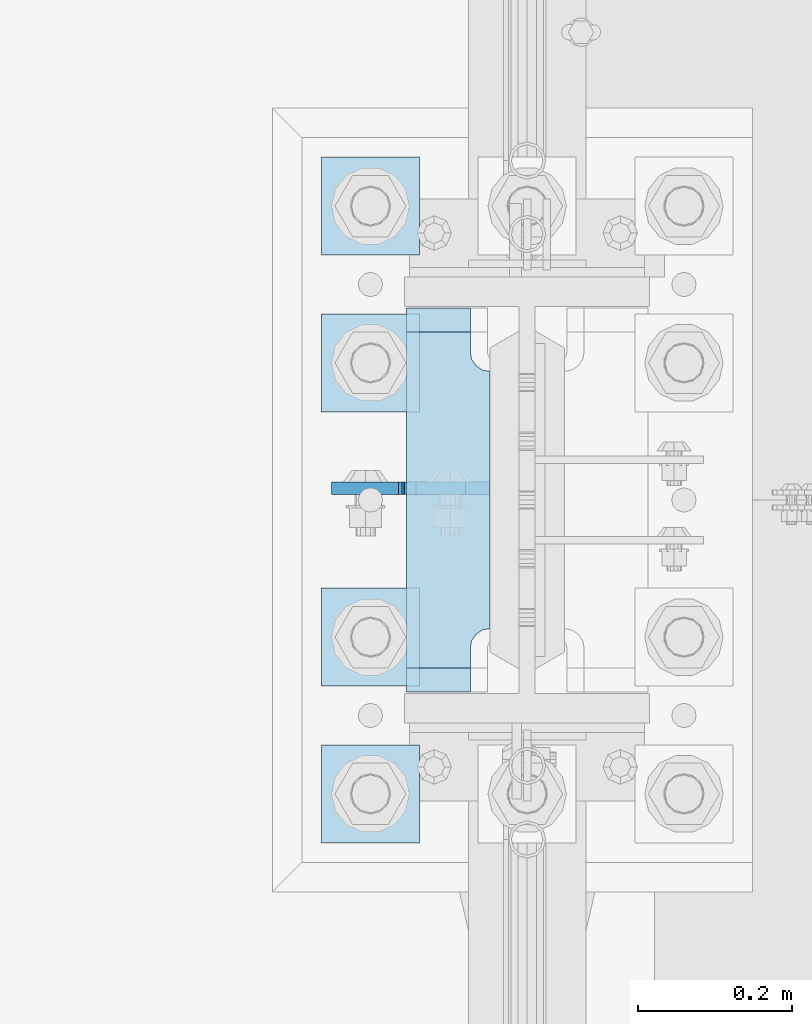
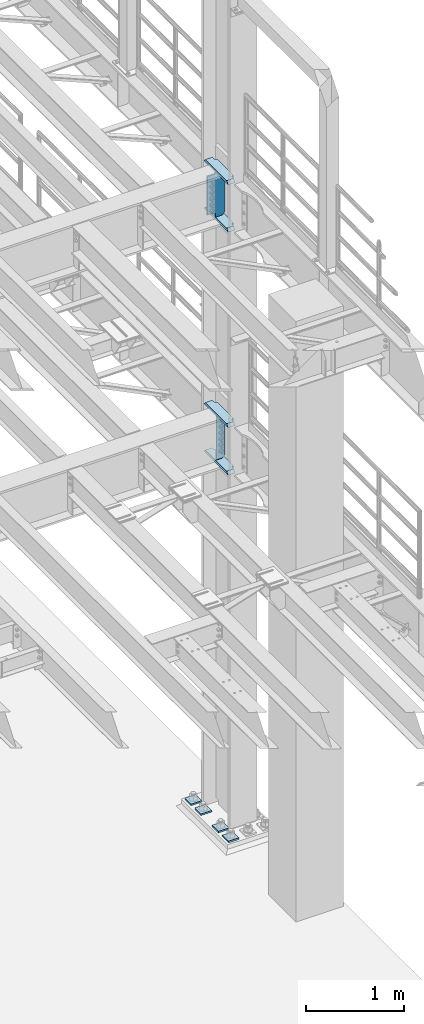
# One storey, part 1736 of 1876: 10 plates, 2 elements without a shape of their own.
"""IFC2X3 building model written with IfcOpenShell, lengths in millimetres."""

from ifc_helpers import new_model, si_unit, frame, origin_with_axes, place, context, subcontext, project, spatial, faceted_brep, material, type_object, element, aggregate, save


model = new_model("IFC2X3")

# Units and contexts
model_context = context("Model", 3, precision=1e-05, world=origin_with_axes())
body_context = subcontext(model_context, "Body", "Model", "MODEL_VIEW")
ifc_project = project(units=[si_unit("LENGTHUNIT", "METRE", prefix="MILLI"), si_unit("AREAUNIT", "SQUARE_METRE"), si_unit("VOLUMEUNIT", "CUBIC_METRE"), si_unit("MASSUNIT", "GRAM", prefix="KILO"), si_unit("TIMEUNIT", "SECOND"), si_unit("PLANEANGLEUNIT", "RADIAN"), si_unit("SOLIDANGLEUNIT", "STERADIAN"), si_unit("THERMODYNAMICTEMPERATUREUNIT", "DEGREE_CELSIUS"), si_unit("LUMINOUSINTENSITYUNIT", "LUMEN")], contexts=[model_context])

# Site, building, storey
site_placement = place(None, origin_with_axes())
site = spatial("IfcSite", under=ifc_project, at=site_placement, CompositionType="ELEMENT")
building_placement = place(site_placement, origin_with_axes())
building = spatial("IfcBuilding", under=site, at=building_placement, Name="Undefined", CompositionType="ELEMENT")
storey_placement = place(building_placement, origin_with_axes())
storey = spatial("IfcBuildingStorey", under=building, at=storey_placement, Name="Undefined", CompositionType="ELEMENT", Elevation=0.0)

# Assembly, plates
assembly_1_placement = place(storey_placement, origin_with_axes())
assembly_1 = element("IfcElementAssembly", 1, at=assembly_1_placement, inside=storey, Name="COLUMN", AssemblyPlace="NOTDEFINED", PredefinedType="RIGID_FRAME")
ifc_material_1 = material(Name="STEEL/A36")
plate_type_1 = type_object("IfcPlateType", PredefinedType="NOTDEFINED")
plate_1_placement = place(assembly_1_placement, frame((7571.58125, 7635.08050012589, 5099.05), z_axis=(-1.0, 0.0, 0.0), x_axis=(0.0, 0.0, -1.0)))
plate_1 = element("IfcPlate", 2, at=plate_1_placement, type_object=plate_type_1, material=ifc_material_1, Name="PLATE", context=body_context, shape_type="Brep", body=[
    faceted_brep([(0.0, -7.93749999999998, 31.75), (0.0, -7.9375, 96.0437469482422), (0.0, 7.9375, 96.0437469482422), (0.0, 7.93749999999999, 31.75), (558.799987792969, -7.9375, 96.0437469482422), (558.799987792969, 7.9375, 96.0437469482422), (558.799987792969, -7.93749999999998, 31.75), (558.799987792969, 7.93749999999999, 31.75), (527.049987792969, -7.93749999999998, 0.0), (527.049987792969, 7.93749999999999, 0.0), (31.75, -7.93749999999998, 0.0), (31.75, 7.93749999999999, 0.0)], [[[0, 1, 2, 3]], [[1, 4, 5, 2]], [[4, 6, 7, 5]], [[6, 8, 9, 7]], [[8, 10, 11, 9]], [[10, 0, 3, 11]], [[5, 7, 9, 11, 3, 2]], [[10, 8, 6, 4, 1, 0]]]),
])
ifc_material_2 = material(Name="STEEL/A572-50")
plate_type_2 = type_object("IfcPlateType", PredefinedType="NOTDEFINED")
plate_2_placement = place(assembly_1_placement, frame((7463.63125, 7869.2375, 7546.97501220703), z_axis=(0.0, -1.0, 0.0), x_axis=(1.0, 0.0, 0.0)))
plate_2 = element("IfcPlate", 3, at=plate_2_placement, type_object=plate_type_2, material=ifc_material_2, Name="PLATE", context=body_context, shape_type="Brep", body=[
    faceted_brep([(82.5499973297119, -15.875, 498.475006103516), (82.5499973297119, 15.875, 467.025007631571), (0.0, 15.875, 467.025007631571), (0.0, -15.875, 498.475006103516), (82.5499973297119, 15.875, 31.449998471945), (82.5499973297119, -15.875, 0.0), (0.0, -15.875, 0.0), (0.0, 15.875, 31.449998471945), (82.5499973297119, 15.875, 57.1500034332275), (82.5499973297119, -15.875, 57.1500034332275), (84.4834571748879, -15.875, 66.8701624693188), (84.4834571748879, 15.875, 66.8701624693188), (89.9894849758439, -15.875, 75.1105154056261), (89.9894849758439, 15.875, 75.1105154056261), (98.2298379121512, -15.875, 80.616543206582), (98.2298379121512, 15.875, 80.616543206582), (107.949996948242, -15.875, 82.5500030517578), (107.949996948242, 15.875, 82.5500030517578), (107.949996948242, -15.875, 415.925003051758), (107.949996948242, 15.875, 415.925003051758), (98.2298379121512, -15.875, 417.858462896934), (98.2298379121512, 15.875, 417.858462896934), (89.9894849758439, -15.875, 423.36449069789), (89.9894849758439, 15.875, 423.36449069789), (84.483457174887, -15.875, 431.604843634197), (84.483457174887, 15.875, 431.604843634197), (82.5499973297119, -15.875, 441.325002670288), (82.5499973297119, 15.875, 441.325002670288)], [[[0, 1, 2, 3]], [[4, 5, 6, 7]], [[8, 9, 5, 4]], [[10, 9, 8, 11]], [[12, 10, 11, 13]], [[14, 12, 13, 15]], [[16, 14, 15, 17]], [[18, 16, 17, 19]], [[20, 18, 19, 21]], [[22, 20, 21, 23]], [[24, 22, 23, 25]], [[26, 24, 25, 27]], [[6, 5, 9, 10, 12, 14, 16, 18, 20, 22, 24, 26, 0, 3]], [[7, 6, 3, 2]], [[27, 25, 23, 21, 19, 17, 15, 13, 11, 8, 4, 7, 2, 1]], [[26, 27, 1, 0]]]),
])
plate_3_placement = place(assembly_1_placement, frame((7463.63125, 7869.2375, 8137.525), z_axis=(0.0, -1.0, 0.0), x_axis=(1.0, 0.0, 0.0)))
plate_3 = element("IfcPlate", 4, at=plate_3_placement, type_object=plate_type_2, material=ifc_material_2, Name="PLATE", context=body_context, shape_type="Brep", body=[
    faceted_brep([(82.5499973297119, -15.875, 498.475006103516), (82.5499973297119, 15.875, 467.025007631571), (0.0, 15.875, 467.025007631571), (0.0, -15.875, 498.475006103516), (82.5499973297119, 15.875, 31.449998471945), (82.5499973297119, -15.875, 0.0), (0.0, -15.875, 0.0), (0.0, 15.875, 31.449998471945), (82.5499973297119, 15.875, 57.1500034332275), (82.5499973297119, -15.875, 57.1500034332275), (84.4834571748879, -15.875, 66.8701624693188), (84.4834571748879, 15.875, 66.8701624693188), (89.9894849758439, -15.875, 75.1105154056261), (89.9894849758439, 15.875, 75.1105154056261), (98.2298379121512, -15.875, 80.616543206582), (98.2298379121512, 15.875, 80.616543206582), (107.949996948242, -15.875, 82.5500030517578), (107.949996948242, 15.875, 82.5500030517578), (107.949996948242, -15.875, 415.925003051758), (107.949996948242, 15.875, 415.925003051758), (98.2298379121512, -15.875, 417.858462896934), (98.2298379121512, 15.875, 417.858462896934), (89.9894849758439, -15.875, 423.36449069789), (89.9894849758439, 15.875, 423.36449069789), (84.483457174887, -15.875, 431.604843634197), (84.483457174887, 15.875, 431.604843634197), (82.5499973297119, -15.875, 441.325002670288), (82.5499973297119, 15.875, 441.325002670288)], [[[0, 1, 2, 3]], [[4, 5, 6, 7]], [[8, 9, 5, 4]], [[10, 9, 8, 11]], [[12, 10, 11, 13]], [[14, 12, 13, 15]], [[16, 14, 15, 17]], [[18, 16, 17, 19]], [[20, 18, 19, 21]], [[22, 20, 21, 23]], [[24, 22, 23, 25]], [[26, 24, 25, 27]], [[6, 5, 9, 10, 12, 14, 16, 18, 20, 22, 24, 26, 0, 3]], [[7, 6, 3, 2]], [[27, 25, 23, 21, 19, 17, 15, 13, 11, 8, 4, 7, 2, 1]], [[26, 27, 1, 0]]]),
])
plate_4_placement = place(assembly_1_placement, frame((7463.63125, 7869.2375, 4524.37501220703), z_axis=(0.0, -1.0, 0.0), x_axis=(1.0, 0.0, 0.0)))
plate_4 = element("IfcPlate", 5, at=plate_4_placement, type_object=plate_type_2, material=ifc_material_2, Name="PLATE", context=body_context, shape_type="Brep", body=[
    faceted_brep([(82.5499973297119, -15.875, 498.475006103516), (82.5499973297119, 15.875, 467.025007631571), (0.0, 15.875, 467.025007631571), (0.0, -15.875, 498.475006103516), (82.5499973297119, 15.875, 31.449998471945), (82.5499973297119, -15.875, 0.0), (0.0, -15.875, 0.0), (0.0, 15.875, 31.449998471945), (82.5499973297119, 15.875, 57.1500034332275), (82.5499973297119, -15.875, 57.1500034332275), (84.4834571748879, -15.875, 66.8701624693188), (84.4834571748879, 15.875, 66.8701624693188), (89.9894849758439, -15.875, 75.1105154056261), (89.9894849758439, 15.875, 75.1105154056261), (98.2298379121512, -15.875, 80.616543206582), (98.2298379121512, 15.875, 80.616543206582), (107.949996948242, -15.875, 82.5500030517578), (107.949996948242, 15.875, 82.5500030517578), (107.949996948242, -15.875, 415.925003051758), (107.949996948242, 15.875, 415.925003051758), (98.2298379121512, -15.875, 417.858462896934), (98.2298379121512, 15.875, 417.858462896934), (89.9894849758439, -15.875, 423.36449069789), (89.9894849758439, 15.875, 423.36449069789), (84.483457174887, -15.875, 431.604843634197), (84.483457174887, 15.875, 431.604843634197), (82.5499973297119, -15.875, 441.325002670288), (82.5499973297119, 15.875, 441.325002670288)], [[[0, 1, 2, 3]], [[4, 5, 6, 7]], [[8, 9, 5, 4]], [[10, 9, 8, 11]], [[12, 10, 11, 13]], [[14, 12, 13, 15]], [[16, 14, 15, 17]], [[18, 16, 17, 19]], [[20, 18, 19, 21]], [[22, 20, 21, 23]], [[24, 22, 23, 25]], [[26, 24, 25, 27]], [[6, 5, 9, 10, 12, 14, 16, 18, 20, 22, 24, 26, 0, 3]], [[7, 6, 3, 2]], [[27, 25, 23, 21, 19, 17, 15, 13, 11, 8, 4, 7, 2, 1]], [[26, 27, 1, 0]]]),
])
plate_5_placement = place(assembly_1_placement, frame((7463.63125, 7869.2375, 5114.925), z_axis=(0.0, -1.0, 0.0), x_axis=(1.0, 0.0, 0.0)))
plate_5 = element("IfcPlate", 6, at=plate_5_placement, type_object=plate_type_2, material=ifc_material_2, Name="PLATE", context=body_context, shape_type="Brep", body=[
    faceted_brep([(82.5499973297119, -15.875, 498.475006103516), (82.5499973297119, 15.875, 467.025007631571), (0.0, 15.875, 467.025007631571), (0.0, -15.875, 498.475006103516), (82.5499973297119, 15.875, 31.449998471945), (82.5499973297119, -15.875, 0.0), (0.0, -15.875, 0.0), (0.0, 15.875, 31.449998471945), (82.5499973297119, 15.875, 57.1500034332275), (82.5499973297119, -15.875, 57.1500034332275), (84.4834571748879, -15.875, 66.8701624693188), (84.4834571748879, 15.875, 66.8701624693188), (89.9894849758439, -15.875, 75.1105154056261), (89.9894849758439, 15.875, 75.1105154056261), (98.2298379121512, -15.875, 80.616543206582), (98.2298379121512, 15.875, 80.616543206582), (107.949996948242, -15.875, 82.5500030517578), (107.949996948242, 15.875, 82.5500030517578), (107.949996948242, -15.875, 415.925003051758), (107.949996948242, 15.875, 415.925003051758), (98.2298379121512, -15.875, 417.858462896934), (98.2298379121512, 15.875, 417.858462896934), (89.9894849758439, -15.875, 423.36449069789), (89.9894849758439, 15.875, 423.36449069789), (84.483457174887, -15.875, 431.604843634197), (84.483457174887, 15.875, 431.604843634197), (82.5499973297119, -15.875, 441.325002670288), (82.5499973297119, 15.875, 441.325002670288)], [[[0, 1, 2, 3]], [[4, 5, 6, 7]], [[8, 9, 5, 4]], [[10, 9, 8, 11]], [[12, 10, 11, 13]], [[14, 12, 13, 15]], [[16, 14, 15, 17]], [[18, 16, 17, 19]], [[20, 18, 19, 21]], [[22, 20, 21, 23]], [[24, 22, 23, 25]], [[26, 24, 25, 27]], [[6, 5, 9, 10, 12, 14, 16, 18, 20, 22, 24, 26, 0, 3]], [[7, 6, 3, 2]], [[27, 25, 23, 21, 19, 17, 15, 13, 11, 8, 4, 7, 2, 1]], [[26, 27, 1, 0]]]),
])
plate_type_3 = type_object("IfcPlateType", PredefinedType="NOTDEFINED")
plate_6_placement = place(assembly_1_placement, frame((7571.58125, 7635.08125, 8121.65), z_axis=(-1.0, 0.0, 0.0), x_axis=(0.0, 0.0, -1.0)))
plate_6 = element("IfcPlate", 7, at=plate_6_placement, type_object=plate_type_3, material=ifc_material_1, Name="PLATE", context=body_context, shape_type="Brep", body=[
    faceted_brep([(501.650012207032, -7.9375, 205.581252728631), (501.650012207032, -7.9375, 123.031246757509), (501.650012207032, 7.9375, 123.031246757509), (501.650012207032, 7.9375, 205.581253051758), (502.61674212962, -7.9375, 118.171167239463), (502.61674212962, 7.9375, 118.171167239463), (505.369756030097, -7.9375, 114.050990771309), (505.369756030097, 7.9375, 114.050990771309), (509.489932498251, -7.9375, 111.297976870831), (509.489932498251, 7.9375, 111.297976870831), (514.350012016297, -7.9375, 110.331246948243), (514.350012016297, 7.9375, 110.331246948243), (558.799987792969, -7.9375, 110.331246948243), (558.799987792969, 7.9375, 110.331246948243), (19.0499992370605, -7.9375, 205.58125), (19.0499992370605, 7.9375, 205.581253051758), (19.0499992370605, 7.9375, 123.031249809265), (19.0499992370605, -7.9375, 123.031249809265), (18.083269314473, 7.9375, 118.17117029122), (18.083269314473, -7.9375, 118.17117029122), (15.3302554139955, 7.9375, 114.050993823066), (15.3302554139955, -7.9375, 114.050993823066), (11.2100789458418, 7.9375, 111.297979922588), (11.2100789458418, -7.9375, 111.297979922588), (6.34999942779541, 7.9375, 110.33125), (6.34999942779541, -7.9375, 110.33125), (0.0, 7.9375, 110.33125), (0.0, -7.9375, 110.33125), (0.0, 7.93749999999999, 31.75), (0.0, -7.93749999999998, 31.75), (31.75, -7.93749999999998, 0.0), (31.75, 7.93749999999999, 0.0), (527.049987792969, -7.93749999999998, 0.0), (527.049987792969, 7.93749999999999, 0.0), (558.799987792969, -7.93749999999998, 31.75), (558.799987792969, 7.93749999999999, 31.75)], [[[0, 1, 2, 3]], [[4, 5, 2, 1]], [[6, 7, 5, 4]], [[8, 9, 7, 6]], [[10, 11, 9, 8]], [[12, 13, 11, 10]], [[14, 15, 16, 17]], [[17, 16, 18, 19]], [[19, 18, 20, 21]], [[21, 20, 22, 23]], [[23, 22, 24, 25]], [[25, 24, 26, 27]], [[28, 29, 27, 26]], [[30, 29, 28, 31]], [[32, 30, 31, 33]], [[34, 32, 33, 35]], [[8, 6, 4, 1, 0, 14, 17, 19, 21, 23, 25, 27, 29, 30, 32, 34, 12, 10]], [[15, 14, 0, 3]], [[35, 33, 31, 28, 26, 24, 22, 20, 18, 16, 15, 3, 2, 5, 7, 9, 11, 13]], [[34, 35, 13, 12]]]),
])
aggregate(assembly_1, [plate_2, plate_3, plate_6, plate_4, plate_5, plate_1])

assembly_2_placement = place(storey_placement, origin_with_axes())
assembly_2 = element("IfcElementAssembly", 8, at=assembly_2_placement, inside=storey, Name="TEMPLATE", AssemblyPlace="NOTDEFINED", PredefinedType="RIGID_FRAME")
plate_type_4 = type_object("IfcPlateType", PredefinedType="NOTDEFINED")
plate_7_placement = place(assembly_2_placement, frame((7480.3, 7302.5, 104.775), z_axis=(-1.0, 0.0, 0.0), x_axis=(0.0, -1.0, 0.0)))
plate_7 = element("IfcPlate", 9, at=plate_7_placement, type_object=plate_type_4, material=ifc_material_2, Name="PLATE WASHER", context=body_context, shape_type="Brep", body=[
    faceted_brep([(-9.09494701772928e-13, -9.525, -1.81898940354586e-12), (0.0, -9.52500000000001, 127.0), (0.0, 9.52500000000001, 127.0), (-9.09494701772928e-13, 9.525, -1.81898940354586e-12), (127.0, -9.52500000000001, 127.0), (127.0, 9.52500000000001, 127.0), (127.0, -9.52500000000001, 0.0), (127.0, 9.52500000000001, 0.0)], [[[0, 1, 2, 3]], [[1, 4, 5, 2]], [[4, 6, 7, 5]], [[6, 0, 3, 7]], [[5, 7, 3, 2]], [[6, 4, 1, 0]]]),
])
plate_8_placement = place(assembly_2_placement, frame((7480.3, 7505.7, 104.775), z_axis=(-1.0, 0.0, 0.0), x_axis=(0.0, -1.0, 0.0)))
plate_8 = element("IfcPlate", 10, at=plate_8_placement, type_object=plate_type_4, material=ifc_material_2, Name="PLATE WASHER", context=body_context, shape_type="Brep", body=[
    faceted_brep([(-9.09494701772928e-13, -9.525, -1.81898940354586e-12), (0.0, -9.52500000000001, 127.0), (0.0, 9.52500000000001, 127.0), (-9.09494701772928e-13, 9.525, -1.81898940354586e-12), (127.0, -9.52500000000001, 127.0), (127.0, 9.52500000000001, 127.0), (127.0, -9.52500000000001, 0.0), (127.0, 9.52500000000001, 0.0)], [[[0, 1, 2, 3]], [[1, 4, 5, 2]], [[4, 6, 7, 5]], [[6, 0, 3, 7]], [[5, 7, 3, 2]], [[6, 4, 1, 0]]]),
])
plate_9_placement = place(assembly_2_placement, frame((7480.3, 7861.3, 104.775), z_axis=(-1.0, 0.0, 0.0), x_axis=(0.0, -1.0, 0.0)))
plate_9 = element("IfcPlate", 11, at=plate_9_placement, type_object=plate_type_4, material=ifc_material_2, Name="PLATE WASHER", context=body_context, shape_type="Brep", body=[
    faceted_brep([(-9.09494701772928e-13, -9.525, -1.81898940354586e-12), (0.0, -9.52500000000001, 127.0), (0.0, 9.52500000000001, 127.0), (-9.09494701772928e-13, 9.525, -1.81898940354586e-12), (127.0, -9.52500000000001, 127.0), (127.0, 9.52500000000001, 127.0), (127.0, -9.52500000000001, 0.0), (127.0, 9.52500000000001, 0.0)], [[[0, 1, 2, 3]], [[1, 4, 5, 2]], [[4, 6, 7, 5]], [[6, 0, 3, 7]], [[5, 7, 3, 2]], [[6, 4, 1, 0]]]),
])
plate_10_placement = place(assembly_2_placement, frame((7480.3, 8064.5, 104.775), z_axis=(-1.0, 0.0, 0.0), x_axis=(0.0, -1.0, 0.0)))
plate_10 = element("IfcPlate", 12, at=plate_10_placement, type_object=plate_type_4, material=ifc_material_2, Name="PLATE WASHER", context=body_context, shape_type="Brep", body=[
    faceted_brep([(-9.09494701772928e-13, -9.525, -1.81898940354586e-12), (0.0, -9.52500000000001, 127.0), (0.0, 9.52500000000001, 127.0), (-9.09494701772928e-13, 9.525, -1.81898940354586e-12), (127.0, -9.52500000000001, 127.0), (127.0, 9.52500000000001, 127.0), (127.0, -9.52500000000001, 0.0), (127.0, 9.52500000000001, 0.0)], [[[0, 1, 2, 3]], [[1, 4, 5, 2]], [[4, 6, 7, 5]], [[6, 0, 3, 7]], [[5, 7, 3, 2]], [[6, 4, 1, 0]]]),
])
aggregate(assembly_2, [plate_7, plate_8, plate_9, plate_10])

save(model, "model.ifc")
